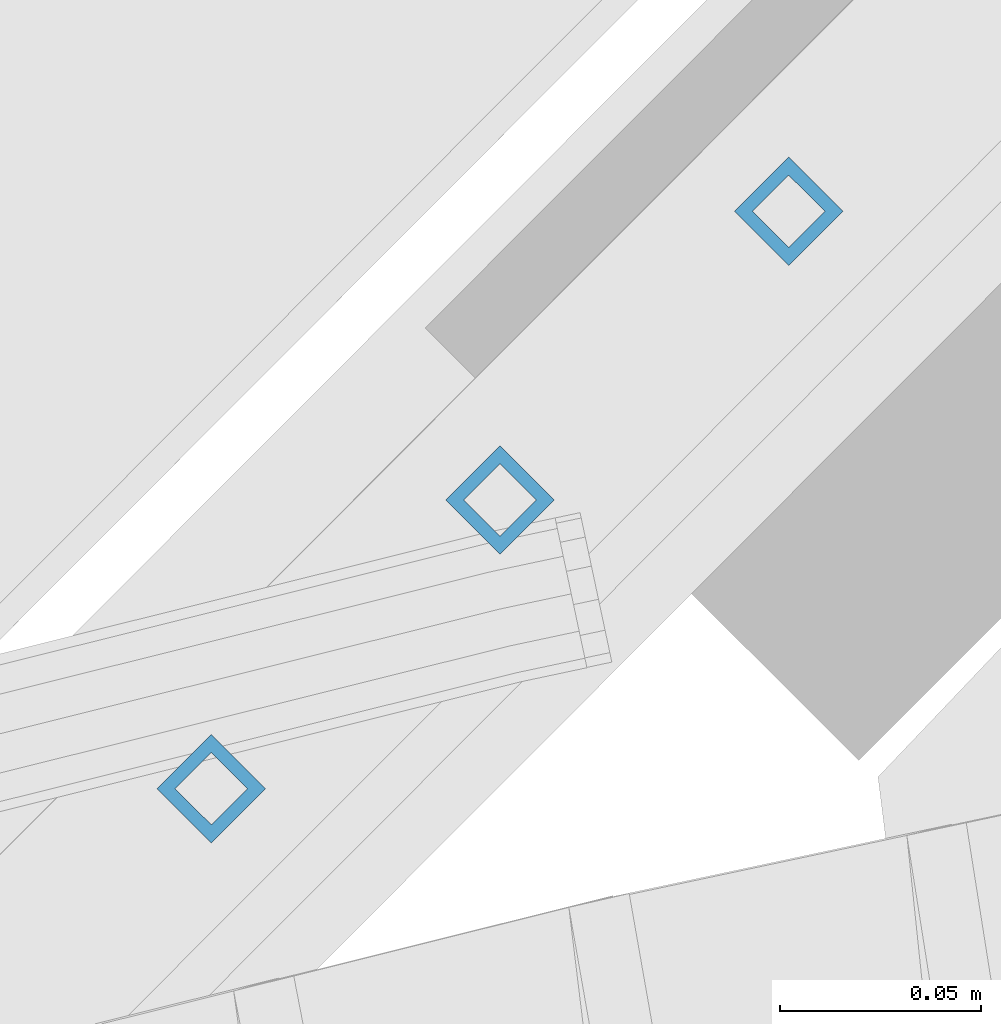
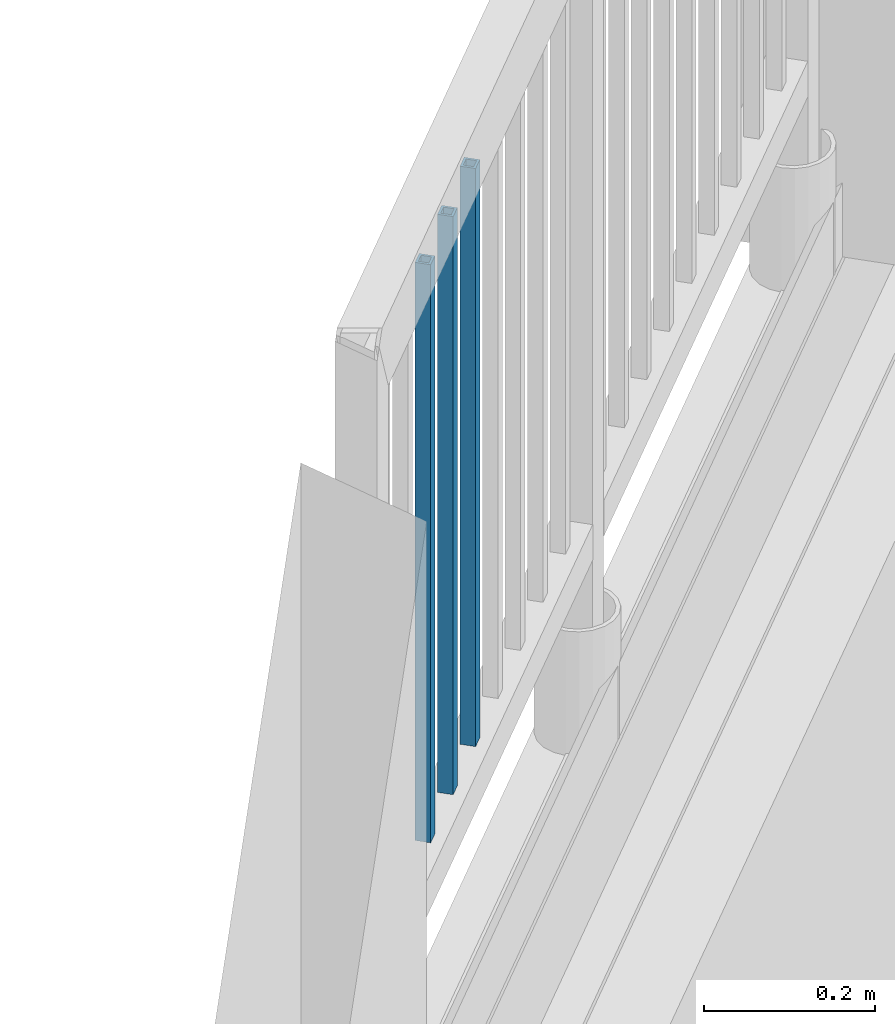
# One storey, part 271 of 975: 3 columns.
"""IFC2X3 building model written with IfcOpenShell, lengths in millimetres."""

from ifc_helpers import new_model, si_unit, frame, origin_with_axes, place, context, subcontext, project, spatial, faceted_brep, material, type_object, element, save


model = new_model("IFC2X3")

# Units and contexts
model_context = context("Model", 3, precision=1e-05, world=origin_with_axes())
body_context = subcontext(model_context, "Body", "Model", "MODEL_VIEW")
ifc_project = project(units=[si_unit("LENGTHUNIT", "METRE", prefix="MILLI"), si_unit("AREAUNIT", "SQUARE_METRE"), si_unit("VOLUMEUNIT", "CUBIC_METRE"), si_unit("MASSUNIT", "GRAM", prefix="KILO"), si_unit("TIMEUNIT", "SECOND"), si_unit("PLANEANGLEUNIT", "RADIAN"), si_unit("SOLIDANGLEUNIT", "STERADIAN"), si_unit("THERMODYNAMICTEMPERATUREUNIT", "DEGREE_CELSIUS"), si_unit("LUMINOUSINTENSITYUNIT", "LUMEN")], contexts=[model_context])

# Site, building, storey
site_placement = place(None, origin_with_axes())
site = spatial("IfcSite", under=ifc_project, at=site_placement, CompositionType="ELEMENT")
building_placement = place(site_placement, origin_with_axes())
building = spatial("IfcBuilding", under=site, at=building_placement, Name="Undefined", CompositionType="ELEMENT")
storey_placement = place(building_placement, origin_with_axes())
storey = spatial("IfcBuildingStorey", under=building, at=storey_placement, Name="Undefined", CompositionType="ELEMENT", Elevation=0.0)

# Columns
ifc_material = material()
column_type = type_object("IfcColumnType", Name="HSS3/4X3/4X.120_TUBES", PredefinedType="NOTDEFINED")
for number, where, z_axis, x_axis, name in (
    (1, (33680.7115987164, 8378.10891871863, 4254.50078114725), (0.706215711946904, 0.707996728946771, 0.0), (0.0, 0.0, 1.0), "PICKET"),
    (2, (33608.8772237164, 8306.27454371863, 4254.50078114725), (0.706215711946904, 0.707996728946771, 0.0), (0.0, 0.0, 1.0), "PICKET"),
    (3, (33537.0428487164, 8234.44016871863, 4254.50078114725), (0.706215711946904, 0.707996728946771, 0.0), (0.0, 0.0, 1.0), "PICKET"),
):
    element("IfcColumn", number, at=place(storey_placement, frame(where, z_axis=z_axis, x_axis=x_axis)), inside=storey, type_object=column_type, material=ifc_material, Name=name, ObjectType="HSS3/4X3/4X.120_TUBES", context=body_context, shape_type="Brep", body=[
        faceted_brep([(0.0, 6.34999999998763, -6.34999999998763), (0.0, -6.35000000000582, -6.34999999998763), (825.49997943247, -6.35000000000582, -6.34999999998763), (825.49997943247, 6.34999999998763, -6.34999999998763), (0.0, -6.34999999998763, 6.34999999998763), (825.49997943247, -6.34999999998763, 6.34999999998763), (0.0, 6.35000000000946, 6.34999999998763), (825.49997943247, 6.35000000000946, 6.34999999998763), (0.0, 9.52499999997963, -9.52499999997963), (0.0, 9.52500000000873, 9.5249999999869), (825.49997943247, 9.52500000000873, 9.5249999999869), (825.49997943247, 9.52499999997963, -9.52499999997963), (0.0, -9.52499999997963, 9.52499999998327), (825.49997943247, -9.52499999997963, 9.52499999998327), (0.0, -9.52500000000873, -9.5249999999869), (825.49997943247, -9.52500000000873, -9.5249999999869)], [[[0, 1, 2, 3]], [[1, 4, 5, 2]], [[4, 6, 7, 5]], [[6, 0, 3, 7]], [[8, 9, 10, 11]], [[9, 12, 13, 10]], [[12, 14, 15, 13]], [[14, 8, 11, 15]], [[13, 15, 11, 10], [5, 7, 3, 2]], [[14, 12, 9, 8], [6, 4, 1, 0]]]),
    ])

save(model, "model.ifc")
